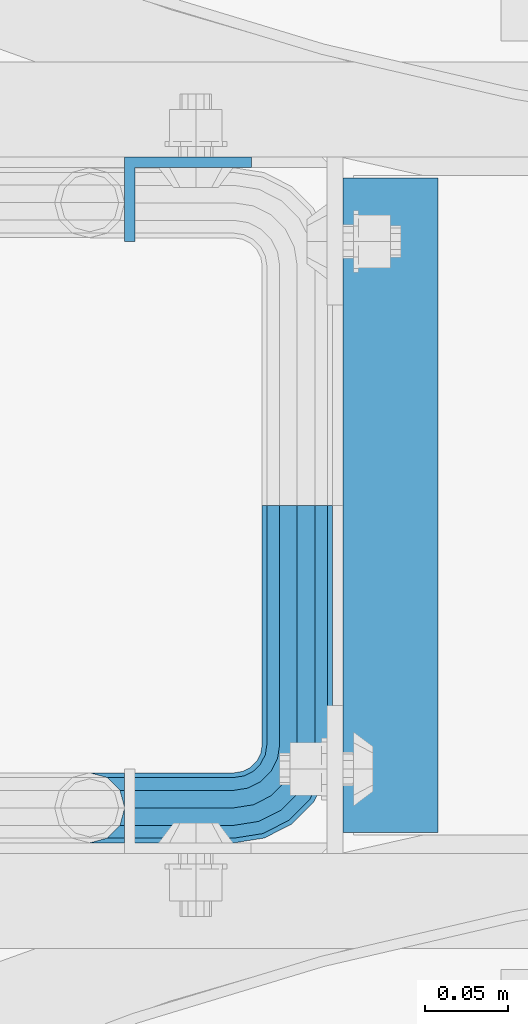
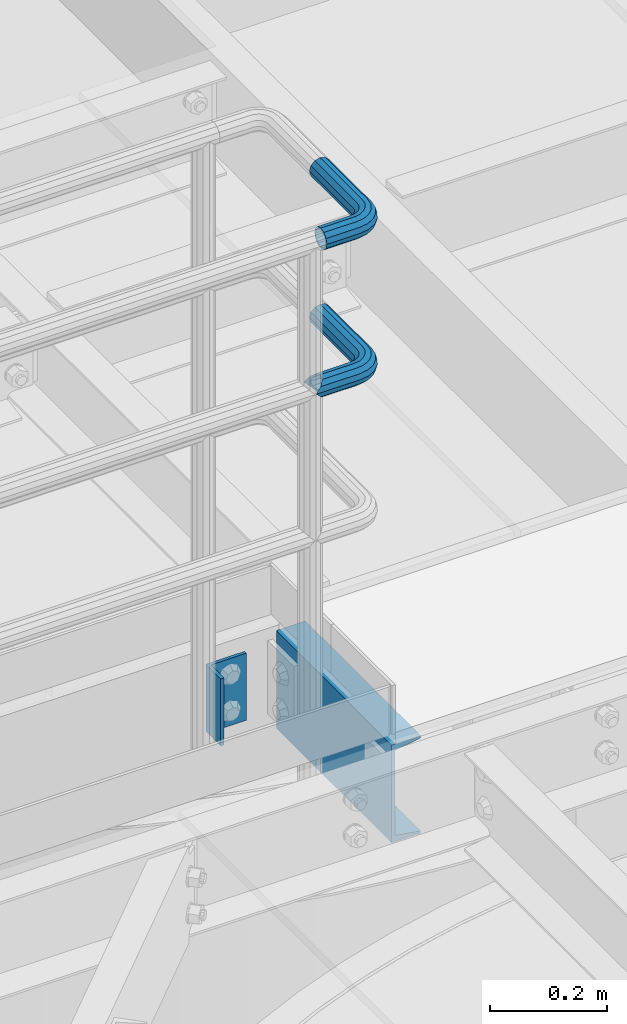
# One storey, part 1114 of 1876: 4 beams, 3 elements without a shape of their own.
"""IFC2X3 building model written with IfcOpenShell, lengths in millimetres."""

from ifc_helpers import new_model, si_unit, frame, origin_with_axes, place, context, subcontext, project, spatial, faceted_brep, material, type_object, element, aggregate, save


model = new_model("IFC2X3")

# Units and contexts
model_context = context("Model", 3, precision=1e-05, world=origin_with_axes())
body_context = subcontext(model_context, "Body", "Model", "MODEL_VIEW")
ifc_project = project(units=[si_unit("LENGTHUNIT", "METRE", prefix="MILLI"), si_unit("AREAUNIT", "SQUARE_METRE"), si_unit("VOLUMEUNIT", "CUBIC_METRE"), si_unit("MASSUNIT", "GRAM", prefix="KILO"), si_unit("TIMEUNIT", "SECOND"), si_unit("PLANEANGLEUNIT", "RADIAN"), si_unit("SOLIDANGLEUNIT", "STERADIAN"), si_unit("THERMODYNAMICTEMPERATUREUNIT", "DEGREE_CELSIUS"), si_unit("LUMINOUSINTENSITYUNIT", "LUMEN")], contexts=[model_context])

# Site, building, storey
site_placement = place(None, origin_with_axes())
site = spatial("IfcSite", under=ifc_project, at=site_placement, CompositionType="ELEMENT")
building_placement = place(site_placement, origin_with_axes())
building = spatial("IfcBuilding", under=site, at=building_placement, Name="Undefined", CompositionType="ELEMENT")
storey_placement = place(building_placement, origin_with_axes())
storey = spatial("IfcBuildingStorey", under=building, at=storey_placement, Name="Undefined", CompositionType="ELEMENT", Elevation=0.0)

# Assembly, beams
assembly_1_placement = place(storey_placement, origin_with_axes())
assembly_1 = element("IfcElementAssembly", 1, at=assembly_1_placement, inside=storey, Name="HANDRAIL", AssemblyPlace="NOTDEFINED", PredefinedType="RIGID_FRAME")
ifc_material_1 = material()
beam_type_1 = type_object("IfcBeamType", Name="PIPE1-1/4STD", PredefinedType="NOTDEFINED")
beam_1_placement = place(assembly_1_placement, frame((4696.96656849878, -11563.3144042962, 8785.225), z_axis=(0.0, 0.0, -1.0), x_axis=(0.0, -1.0, 0.0)))
beam_1 = element("IfcBeam", 2, at=beam_1_placement, type_object=beam_type_1, material=ifc_material_1, Name="HANDRAIL", ObjectType="PIPE1-1/4STD", context=body_context, shape_type="Brep", body=[
    faceted_brep([(192.659041992189, 106.710451704997, 18.2575475625836), (192.659048095087, 106.710451704997, 13.3999551238248), (190.881041992188, 106.234036405587, 15.1779612267255), (182.118041992188, 103.88599926758, 17.5259999999998), (182.118041992188, 103.88599926758, 21.0820000000003), (173.355041992188, 106.234039676121, 15.1779612267255), (171.577048095089, 106.710451704997, 13.3999673296257), (171.577041992188, 106.710451704997, 18.2575475625836), (163.860494429604, 114.42699926758, 10.5409999999993), (163.860494429604, 114.42699926758, -10.5409999999993), (161.036041992187, 124.968002319336, 0.0), (166.940080765462, 111.347419034623, 8.76300000000083), (164.592041992188, 113.695457807897, 0.0), (166.940080765462, 111.347419034623, -8.76300000000083), (171.577048095089, 106.710451704997, -13.3999673296257), (171.577041992188, 106.710451704997, -18.2575475625836), (182.118041992188, 103.88599926758, -17.5259999999998), (182.118041992188, 103.88599926758, -21.0820000000003), (173.355041992188, 106.234039676121, -15.1779612267255), (192.659048095087, 106.710451704997, -13.3999551238248), (192.659041992189, 106.710451704997, -18.2575475625836), (190.881041992188, 106.234036405587, -15.1779612267255), (203.200048095088, 124.96799926758, 0.0), (200.375589554771, 114.42699926758, -10.5409999999993), (200.375589554771, 114.42699926758, 10.5409999999993), (197.296003218913, 111.347406828822, -8.76300000000083), (199.644041992187, 113.695445602096, 0.0), (197.296003218913, 111.347406828822, 8.76300000000083), (0.0, -18.2575475625836, -10.5409999999993), (0.0, -10.5410000000002, -18.2575475625836), (144.018043518066, -10.5409999999983, -18.2575475625836), (144.018043518066, -18.2575475625817, -10.5409999999993), (-4.28826751885936e-09, 0.0, -21.0820000000003), (144.018043518066, 1.81898940354586e-12, -21.0820000000003), (0.0, 10.5410000000002, -18.2575475625836), (144.018043518066, 10.5410000000011, -18.2575475625836), (0.0, 18.2575475625836, -10.5409999999993), (144.018043518066, 18.2575475625854, -10.5409999999993), (9.09494701772928e-13, 21.0820000000003, 0.0), (144.018043518066, 21.0820000000012, 0.0), (0.0, 18.2575475625836, 10.5409999999993), (144.018043518066, 18.2575475625854, 10.5409999999993), (0.0, 10.5410000000002, 18.2575475625836), (144.018043518066, 10.5410000000011, 18.2575475625836), (0.0, 0.0, 21.0820000000003), (144.018043518066, 1.81898940354586e-12, 21.0820000000003), (0.0, -10.5410000000002, 18.2575475625836), (144.018043518066, -10.5409999999983, 18.2575475625836), (0.0, -18.2575475625836, 10.5409999999993), (144.018043518066, -18.2575475625817, 10.5409999999993), (9.09494701772928e-13, -21.0820000000003, 0.0), (144.018043518066, -21.0819999999985, 0.0), (162.306286807647, -18.1854268220595, 0.0), (161.433483004681, -15.4992129264883, 10.5409999999993), (159.048938669939, -8.16034008379211, 18.2575475625836), (155.791590532232, 1.86474665447531, 21.0820000000003), (152.534242394526, 11.8898333927418, 18.2575475625836), (150.149698059784, 19.228706235438, 10.5409999999993), (149.276894256818, 21.9149201310092, 0.0), (150.149698059784, 19.2287062354389, -10.5409999999993), (152.534242394526, 11.8898333927418, -18.2575475625836), (155.791590532232, 1.86474665447531, -21.0820000000003), (159.048938669939, -8.16034008379211, -18.2575475625836), (161.433483004681, -15.4992129264883, -10.5409999999993), (163.860494429606, 38.0999984741229, -10.5409999999993), (161.036041992189, 38.0999984741229, 0.0), (163.860494429606, 38.0999984741229, 10.5409999999993), (171.57704199219, 38.0999984741229, 18.2575475625836), (182.118041992189, 38.099998474122, 21.0820000000003), (192.65904199219, 38.099998474122, 18.2575475625836), (200.375589554773, 38.099998474122, 10.5409999999993), (203.200041992188, 38.0999984741229, 0.0), (182.118041992189, 38.099998474122, -21.0820000000003), (171.57704199219, 38.0999984741229, -18.2575475625836), (192.65904199219, 38.099998474122, -18.2575475625836), (200.375589554773, 38.099998474122, -10.5409999999993), (162.889335756752, 31.9683439324062, -10.5409999999993), (170.228208599448, 29.5837995976653, -18.2575475625836), (160.203121861181, 32.841147735372, 0.0), (162.889335756752, 31.9683439324062, 10.5409999999993), (170.228208599448, 29.5837995976653, 18.2575475625836), (180.253295337716, 26.3264514599587, 21.0820000000003), (190.278382075983, 23.069103322252, 18.2575475625836), (197.617254918679, 20.6845589875102, 10.5409999999993), (200.303468814251, 19.8117551845444, 0.0), (197.617254918679, 20.6845589875102, -10.5409999999993), (190.278382075983, 23.069103322252, -18.2575475625836), (180.253295337716, 26.3264514599587, -21.0820000000003), (166.313741631582, 21.9012256030801, -18.2575475625836), (174.841589769288, 15.7053812586637, -21.0820000000003), (160.07092351555, 26.436898458981, -10.5409999999993), (157.785893493878, 28.0970699474965, 0.0), (160.07092351555, 26.436898458981, 10.5409999999993), (166.313741631582, 21.9012256030801, 18.2575475625836), (174.841589769288, 15.7053812586637, 21.0820000000003), (183.369437906993, 9.50953691424729, 18.2575475625836), (189.612256023025, 4.97386405834641, 10.5409999999993), (191.897286044699, 3.31369256983089, 0.0), (189.612256023025, 4.97386405834641, -10.5409999999993), (183.369437906993, 9.50953691424729, -18.2575475625836), (166.412660733527, 7.27645222290266, -21.0820000000003), (172.608505077944, -1.25139591480183, -18.2575475625836), (160.216816389111, 15.8043003606081, -18.2575475625836), (155.681143533209, 22.0471184766402, -10.5409999999993), (154.020972044695, 24.3321484983135, 0.0), (155.681143533209, 22.0471184766402, 10.5409999999993), (160.216816389111, 15.8043003606081, 18.2575475625836), (166.412660733527, 7.27645222290266, 21.0820000000003), (172.608505077944, -1.25139591480183, 18.2575475625836), (177.144177933844, -7.49421403083397, 10.5409999999993), (178.80434942236, -9.77924405250724, 0.0), (177.144177933844, -7.49421403083397, -10.5409999999993), (0.0, -15.1779612267264, -8.76300000000083), (0.0, -8.76299999999992, -15.1779612267255), (0.0, 0.0, -17.5259999999998), (0.0, 8.76299999999992, -15.1779612267255), (0.0, 15.1779612267264, -8.76300000000083), (0.0, 17.5259999999998, 0.0), (0.0, 15.1779612267264, 8.76300000000083), (0.0, 8.76299999999992, 15.1779612267255), (0.0, 0.0, 17.5259999999998), (0.0, -8.76299999999992, 15.1779612267255), (0.0, -15.1779612267264, 8.76300000000083), (0.0, -17.5259999999998, 0.0), (144.018043518066, -8.7629999999981, 15.1779612267255), (144.018043518066, -15.1779612267246, 8.76300000000083), (144.018043518066, -17.5259999999989, 0.0), (144.018043518066, -15.1779612267246, -8.76300000000083), (144.018043518066, -8.76299999999901, -15.1779612267255), (144.018043518066, 1.81898940354586e-12, -17.5259999999998), (144.018043518066, 8.76300000000174, -15.1779612267255), (144.018043518066, 15.1779612267273, -8.76300000000083), (144.018043518066, 17.5260000000017, 0.0), (144.018043518066, 15.1779612267273, 8.76300000000083), (144.018043518066, 8.76300000000174, 15.1779612267255), (144.018043518066, 1.81898940354586e-12, 17.5259999999998), (155.791590532232, 1.86474665447531, 17.5259999999998), (158.49950645394, -6.46936159781944, 15.1779612267255), (160.481838491256, -12.5703522742779, 8.76300000000083), (161.207422375648, -14.8034698501133, 0.0), (160.481838491256, -12.5703522742779, -8.76300000000083), (158.49950645394, -6.46936159781944, -15.1779612267255), (155.791590532232, 1.86474665447531, -17.5259999999998), (153.083674610523, 10.1988549067692, -15.1779612267255), (151.101342573209, 16.2998455832276, -8.76300000000083), (150.375758688817, 18.5329631590639, 0.0), (151.101342573209, 16.2998455832276, 8.76300000000083), (153.083674610523, 10.1988549067692, 15.1779612267255), (161.261898567687, 14.3658681446095, 15.1779612267255), (166.412660733527, 7.27645222290266, 17.5259999999998), (157.491278964588, 19.5556807952871, 8.76300000000083), (156.111136401847, 21.4552840663164, 0.0), (157.491278964588, 19.5556807952871, -8.76300000000083), (161.261898567687, 14.3658681446095, -15.1779612267255), (166.412660733527, 7.27645222290266, -17.5259999999998), (171.563422899368, 0.187036301196713, -15.1779612267255), (175.334042502465, -5.00277634948088, -8.76300000000083), (176.714185065208, -6.90237962051015, 0.0), (175.334042502465, -5.00277634948088, 8.76300000000083), (171.563422899368, 0.187036301196713, 15.1779612267255), (174.841589769288, 15.7053812586637, 17.5259999999998), (181.931005690994, 10.5546190928235, 15.1779612267255), (167.752173847581, 20.8561434245039, 15.1779612267255), (162.562361196904, 24.6267630276025, 8.76300000000083), (160.662757925875, 26.0069055903441, 0.0), (162.562361196904, 24.6267630276025, -8.76300000000083), (167.752173847581, 20.8561434245039, -15.1779612267255), (174.841589769288, 15.7053812586637, -17.5259999999998), (181.931005690994, 10.5546190928235, -15.1779612267255), (187.120818341671, 6.78399948972492, -8.76300000000083), (189.020421612702, 5.40385692698328, 0.0), (187.120818341671, 6.78399948972492, 8.76300000000083), (188.587403590011, 23.6185355382504, 15.1779612267255), (194.688394266468, 21.6362035009352, 8.76300000000083), (180.253295337716, 26.3264514599587, 17.5259999999998), (171.919187085421, 29.0343673816669, 15.1779612267255), (165.818196408964, 31.0166994189813, 8.76300000000083), (163.585078833126, 31.7422833033743, 0.0), (165.818196408964, 31.0166994189813, -8.76300000000083), (171.919187085421, 29.0343673816669, -15.1779612267255), (180.253295337716, 26.3264514599587, -17.5259999999998), (188.587403590011, 23.6185355382504, -15.1779612267255), (194.688394266468, 21.6362035009352, -8.76300000000083), (196.921511842305, 20.9106196165421, 0.0), (197.296003218915, 38.099998474122, 8.76300000000083), (199.644041992187, 38.0999984741229, 0.0), (190.88104199219, 38.099998474122, 15.1779612267255), (182.118041992189, 38.099998474122, 17.5259999999998), (173.355041992188, 38.099998474122, 15.1779612267255), (166.940080765464, 38.0999984741229, 8.76300000000083), (164.592041992189, 38.0999984741229, 0.0), (166.940080765464, 38.0999984741229, -8.76300000000083), (173.355041992188, 38.0999984741229, -15.1779612267255), (182.118041992189, 38.099998474122, -17.5259999999998), (190.88104199219, 38.099998474122, -15.1779612267255), (197.296003218915, 38.099998474122, -8.76300000000083)], [[[0, 1, 2, 3, 4]], [[4, 3, 5, 6, 7]], [[8, 9, 10]], [[7, 6, 11, 12, 13, 14, 15, 9, 8]], [[16, 17, 15, 14, 18]], [[19, 20, 17, 16, 21]], [[22, 23, 24]], [[24, 23, 20, 19, 25, 26, 27, 1, 0]], [[28, 29, 30, 31]], [[29, 32, 33, 30]], [[32, 34, 35, 33]], [[34, 36, 37, 35]], [[36, 38, 39, 37]], [[38, 40, 41, 39]], [[40, 42, 43, 41]], [[42, 44, 45, 43]], [[44, 46, 47, 45]], [[46, 48, 49, 47]], [[48, 50, 51, 49]], [[49, 51, 52, 53]], [[47, 49, 53, 54]], [[45, 47, 54, 55]], [[43, 45, 55, 56]], [[41, 43, 56, 57]], [[39, 41, 57, 58]], [[37, 39, 58, 59]], [[35, 37, 59, 60]], [[33, 35, 60, 61]], [[30, 33, 61, 62]], [[31, 30, 62, 63]], [[64, 65, 10, 9]], [[65, 66, 8, 10]], [[66, 67, 7, 8]], [[67, 68, 4, 7]], [[68, 69, 0, 4]], [[69, 70, 24, 0]], [[70, 71, 22, 24]], [[72, 73, 15, 17]], [[74, 72, 17, 20]], [[75, 74, 20, 23]], [[71, 75, 23, 22]], [[73, 64, 9, 15]], [[76, 64, 73, 77]], [[78, 65, 64, 76]], [[79, 66, 65, 78]], [[80, 67, 66, 79]], [[81, 68, 67, 80]], [[82, 69, 68, 81]], [[83, 70, 69, 82]], [[84, 71, 70, 83]], [[85, 75, 71, 84]], [[86, 74, 75, 85]], [[87, 72, 74, 86]], [[77, 73, 72, 87]], [[88, 77, 87, 89]], [[90, 76, 77, 88]], [[91, 78, 76, 90]], [[92, 79, 78, 91]], [[93, 80, 79, 92]], [[94, 81, 80, 93]], [[95, 82, 81, 94]], [[96, 83, 82, 95]], [[97, 84, 83, 96]], [[98, 85, 84, 97]], [[99, 86, 85, 98]], [[89, 87, 86, 99]], [[100, 89, 99, 101]], [[102, 88, 89, 100]], [[103, 90, 88, 102]], [[104, 91, 90, 103]], [[105, 92, 91, 104]], [[106, 93, 92, 105]], [[107, 94, 93, 106]], [[108, 95, 94, 107]], [[109, 96, 95, 108]], [[110, 97, 96, 109]], [[111, 98, 97, 110]], [[101, 99, 98, 111]], [[62, 101, 111, 63]], [[61, 100, 101, 62]], [[60, 102, 100, 61]], [[59, 103, 102, 60]], [[58, 104, 103, 59]], [[57, 105, 104, 58]], [[56, 106, 105, 57]], [[55, 107, 106, 56]], [[54, 108, 107, 55]], [[53, 109, 108, 54]], [[52, 110, 109, 53]], [[63, 111, 110, 52]], [[51, 31, 63, 52]], [[50, 28, 31, 51]], [[48, 46, 44, 42, 40, 38, 36, 34, 32, 29, 28, 50], [112, 113, 114, 115, 116, 117, 118, 119, 120, 121, 122, 123]], [[122, 121, 124, 125]], [[123, 122, 125, 126]], [[112, 123, 126, 127]], [[113, 112, 127, 128]], [[114, 113, 128, 129]], [[115, 114, 129, 130]], [[116, 115, 130, 131]], [[117, 116, 131, 132]], [[118, 117, 132, 133]], [[119, 118, 133, 134]], [[120, 119, 134, 135]], [[121, 120, 135, 124]], [[124, 135, 136, 137]], [[125, 124, 137, 138]], [[126, 125, 138, 139]], [[127, 126, 139, 140]], [[128, 127, 140, 141]], [[129, 128, 141, 142]], [[130, 129, 142, 143]], [[131, 130, 143, 144]], [[132, 131, 144, 145]], [[133, 132, 145, 146]], [[134, 133, 146, 147]], [[135, 134, 147, 136]], [[147, 148, 149, 136]], [[146, 150, 148, 147]], [[145, 151, 150, 146]], [[144, 152, 151, 145]], [[143, 153, 152, 144]], [[142, 154, 153, 143]], [[141, 155, 154, 142]], [[140, 156, 155, 141]], [[139, 157, 156, 140]], [[138, 158, 157, 139]], [[137, 159, 158, 138]], [[136, 149, 159, 137]], [[149, 160, 161, 159]], [[148, 162, 160, 149]], [[150, 163, 162, 148]], [[151, 164, 163, 150]], [[152, 165, 164, 151]], [[153, 166, 165, 152]], [[154, 167, 166, 153]], [[155, 168, 167, 154]], [[156, 169, 168, 155]], [[157, 170, 169, 156]], [[158, 171, 170, 157]], [[159, 161, 171, 158]], [[161, 172, 173, 171]], [[160, 174, 172, 161]], [[162, 175, 174, 160]], [[163, 176, 175, 162]], [[164, 177, 176, 163]], [[165, 178, 177, 164]], [[166, 179, 178, 165]], [[167, 180, 179, 166]], [[168, 181, 180, 167]], [[169, 182, 181, 168]], [[170, 183, 182, 169]], [[171, 173, 183, 170]], [[173, 184, 185, 183]], [[172, 186, 184, 173]], [[174, 187, 186, 172]], [[175, 188, 187, 174]], [[176, 189, 188, 175]], [[177, 190, 189, 176]], [[178, 191, 190, 177]], [[179, 192, 191, 178]], [[180, 193, 192, 179]], [[181, 194, 193, 180]], [[182, 195, 194, 181]], [[183, 185, 195, 182]], [[195, 185, 26, 25]], [[21, 194, 195, 25, 19]], [[193, 194, 21, 16]], [[192, 193, 16, 18]], [[13, 191, 192, 18, 14]], [[190, 191, 13, 12]], [[189, 190, 12, 11]], [[188, 189, 11, 6, 5]], [[187, 188, 5, 3]], [[186, 187, 3, 2]], [[184, 186, 2, 1, 27]], [[185, 184, 27, 26]]]),
])
beam_2_placement = place(assembly_1_placement, frame((4696.96656849878, -11563.3144042962, 9090.025), z_axis=(0.0, 0.0, -1.0), x_axis=(0.0, -1.0, 0.0)))
beam_2 = element("IfcBeam", 3, at=beam_2_placement, type_object=beam_type_1, material=ifc_material_1, Name="HANDRAIL", ObjectType="PIPE1-1/4STD", context=body_context, shape_type="Brep", body=[
    faceted_brep([(9.09494701772928e-13, -21.0820000000003, 0.0), (0.0, -18.2575475625836, -10.5409999999993), (144.018043518066, -18.2575475625817, -10.5409999999993), (144.018043518066, -21.0819999999985, 0.0), (0.0, -10.5410000000002, -18.2575475625836), (144.018043518066, -10.5409999999983, -18.2575475625836), (-4.28826751885936e-09, 0.0, -21.0820000000003), (144.018043518066, 1.81898940354586e-12, -21.0820000000003), (0.0, 10.5410000000002, -18.2575475625836), (144.018043518066, 10.5410000000011, -18.2575475625836), (0.0, 18.2575475625836, -10.5409999999993), (144.018043518066, 18.2575475625854, -10.5409999999993), (9.09494701772928e-13, 21.0820000000003, 0.0), (144.018043518066, 21.0820000000012, 0.0), (0.0, 18.2575475625836, 10.5409999999993), (144.018043518066, 18.2575475625854, 10.5409999999993), (0.0, 10.5410000000002, 18.2575475625836), (144.018043518066, 10.5410000000011, 18.2575475625836), (0.0, 0.0, 21.0820000000003), (144.018043518066, 1.81898940354586e-12, 21.0820000000003), (0.0, -10.5410000000002, 18.2575475625836), (144.018043518066, -10.5409999999983, 18.2575475625836), (0.0, -18.2575475625836, 10.5409999999993), (144.018043518066, -18.2575475625817, 10.5409999999993), (0.0, -17.5259999999998, 0.0), (0.0, -15.1779612267264, 8.76300000000083), (144.018043518066, -15.1779612267246, 8.76300000000083), (144.018043518066, -17.5259999999989, 0.0), (0.0, -8.76299999999992, 15.1779612267255), (144.018043518066, -8.7629999999981, 15.1779612267255), (0.0, 0.0, 17.5259999999998), (144.018043518066, 1.81898940354586e-12, 17.5259999999998), (0.0, 8.76299999999992, 15.1779612267255), (144.018043518066, 8.76300000000174, 15.1779612267255), (0.0, 15.1779612267264, 8.76300000000083), (144.018043518066, 15.1779612267273, 8.76300000000083), (0.0, 17.5259999999998, 0.0), (144.018043518066, 17.5260000000017, 0.0), (0.0, 15.1779612267264, -8.76300000000083), (144.018043518066, 15.1779612267273, -8.76300000000083), (0.0, 8.76299999999992, -15.1779612267255), (144.018043518066, 8.76300000000174, -15.1779612267255), (0.0, 0.0, -17.5259999999998), (144.018043518066, 1.81898940354586e-12, -17.5259999999998), (0.0, -8.76299999999992, -15.1779612267255), (144.018043518066, -8.76299999999901, -15.1779612267255), (0.0, -15.1779612267264, -8.76300000000083), (144.018043518066, -15.1779612267246, -8.76300000000083), (162.306286807647, -18.1854268220595, 0.0), (161.433483004681, -15.4992129264883, 10.5409999999993), (159.048938669939, -8.16034008379211, 18.2575475625836), (155.791590532232, 1.86474665447531, 21.0820000000003), (152.534242394526, 11.8898333927418, 18.2575475625836), (150.149698059784, 19.228706235438, 10.5409999999993), (149.276894256818, 21.9149201310092, 0.0), (150.149698059784, 19.2287062354389, -10.5409999999993), (152.534242394526, 11.8898333927418, -18.2575475625836), (155.791590532232, 1.86474665447531, -21.0820000000003), (159.048938669939, -8.16034008379211, -18.2575475625836), (161.433483004681, -15.4992129264883, -10.5409999999993), (161.207422375648, -14.8034698501133, 0.0), (160.481838491256, -12.5703522742779, -8.76300000000083), (158.49950645394, -6.46936159781944, -15.1779612267255), (155.791590532232, 1.86474665447531, -17.5259999999998), (153.083674610523, 10.1988549067692, -15.1779612267255), (151.101342573209, 16.2998455832276, -8.76300000000083), (150.375758688817, 18.5329631590639, 0.0), (151.101342573209, 16.2998455832276, 8.76300000000083), (153.083674610523, 10.1988549067692, 15.1779612267255), (155.791590532232, 1.86474665447531, 17.5259999999998), (158.49950645394, -6.46936159781944, 15.1779612267255), (160.481838491256, -12.5703522742779, 8.76300000000083), (172.608505077944, -1.25139591480183, -18.2575475625836), (177.144177933844, -7.49421403083397, -10.5409999999993), (166.412660733527, 7.27645222290266, -21.0820000000003), (160.216816389111, 15.8043003606081, -18.2575475625836), (155.681143533209, 22.0471184766402, -10.5409999999993), (154.020972044695, 24.3321484983135, 0.0), (155.681143533209, 22.0471184766402, 10.5409999999993), (160.216816389111, 15.8043003606081, 18.2575475625836), (166.412660733527, 7.27645222290266, 21.0820000000003), (172.608505077944, -1.25139591480183, 18.2575475625836), (177.144177933844, -7.49421403083397, 10.5409999999993), (178.80434942236, -9.77924405250724, 0.0), (175.334042502465, -5.00277634948088, 8.76300000000083), (176.714185065208, -6.90237962051015, 0.0), (171.563422899368, 0.187036301196713, 15.1779612267255), (166.412660733527, 7.27645222290266, 17.5259999999998), (161.261898567687, 14.3658681446095, 15.1779612267255), (157.491278964588, 19.5556807952871, 8.76300000000083), (156.111136401847, 21.4552840663164, 0.0), (157.491278964588, 19.5556807952871, -8.76300000000083), (161.261898567687, 14.3658681446095, -15.1779612267255), (166.412660733527, 7.27645222290266, -17.5259999999998), (171.563422899368, 0.187036301196713, -15.1779612267255), (175.334042502465, -5.00277634948088, -8.76300000000083), (183.369437906993, 9.50953691424729, -18.2575475625836), (189.612256023025, 4.97386405834641, -10.5409999999993), (174.841589769288, 15.7053812586637, -21.0820000000003), (166.313741631582, 21.9012256030801, -18.2575475625836), (160.07092351555, 26.436898458981, -10.5409999999993), (157.785893493878, 28.0970699474965, 0.0), (160.07092351555, 26.436898458981, 10.5409999999993), (166.313741631582, 21.9012256030801, 18.2575475625836), (174.841589769288, 15.7053812586637, 21.0820000000003), (183.369437906993, 9.50953691424729, 18.2575475625836), (189.612256023025, 4.97386405834641, 10.5409999999993), (191.897286044699, 3.31369256983089, 0.0), (187.120818341671, 6.78399948972492, 8.76300000000083), (189.020421612702, 5.40385692698328, 0.0), (181.931005690994, 10.5546190928235, 15.1779612267255), (174.841589769288, 15.7053812586637, 17.5259999999998), (167.752173847581, 20.8561434245039, 15.1779612267255), (162.562361196904, 24.6267630276025, 8.76300000000083), (160.662757925875, 26.0069055903441, 0.0), (162.562361196904, 24.6267630276025, -8.76300000000083), (167.752173847581, 20.8561434245039, -15.1779612267255), (174.841589769288, 15.7053812586637, -17.5259999999998), (181.931005690994, 10.5546190928235, -15.1779612267255), (187.120818341671, 6.78399948972492, -8.76300000000083), (190.278382075983, 23.069103322252, -18.2575475625836), (197.617254918679, 20.6845589875102, -10.5409999999993), (180.253295337716, 26.3264514599587, -21.0820000000003), (170.228208599448, 29.5837995976653, -18.2575475625836), (162.889335756752, 31.9683439324062, -10.5409999999993), (160.203121861181, 32.841147735372, 0.0), (162.889335756752, 31.9683439324062, 10.5409999999993), (170.228208599448, 29.5837995976653, 18.2575475625836), (180.253295337716, 26.3264514599587, 21.0820000000003), (190.278382075983, 23.069103322252, 18.2575475625836), (197.617254918679, 20.6845589875102, 10.5409999999993), (200.303468814251, 19.8117551845444, 0.0), (194.688394266468, 21.6362035009352, 8.76300000000083), (196.921511842305, 20.9106196165421, 0.0), (188.587403590011, 23.6185355382504, 15.1779612267255), (180.253295337716, 26.3264514599587, 17.5259999999998), (171.919187085421, 29.0343673816669, 15.1779612267255), (165.818196408964, 31.0166994189813, 8.76300000000083), (163.585078833126, 31.7422833033743, 0.0), (165.818196408964, 31.0166994189813, -8.76300000000083), (171.919187085421, 29.0343673816669, -15.1779612267255), (180.253295337716, 26.3264514599587, -17.5259999999998), (188.587403590011, 23.6185355382504, -15.1779612267255), (194.688394266468, 21.6362035009352, -8.76300000000083), (192.65904199219, 38.099998474122, -18.2575475625836), (200.375589554773, 38.099998474122, -10.5409999999993), (182.118041992189, 38.099998474122, -21.0820000000003), (171.57704199219, 38.0999984741229, -18.2575475625836), (163.860494429606, 38.0999984741229, -10.5409999999993), (161.036041992189, 38.0999984741229, 0.0), (163.860494429606, 38.0999984741229, 10.5409999999993), (171.57704199219, 38.0999984741229, 18.2575475625836), (182.118041992189, 38.099998474122, 21.0820000000003), (192.65904199219, 38.099998474122, 18.2575475625836), (200.375589554773, 38.099998474122, 10.5409999999993), (203.200041992188, 38.0999984741229, 0.0), (197.296003218915, 38.099998474122, 8.76300000000083), (199.644041992187, 38.0999984741229, 0.0), (190.88104199219, 38.099998474122, 15.1779612267255), (182.118041992189, 38.099998474122, 17.5259999999998), (173.355041992188, 38.099998474122, 15.1779612267255), (166.940080765464, 38.0999984741229, 8.76300000000083), (164.592041992189, 38.0999984741229, 0.0), (166.940080765464, 38.0999984741229, -8.76300000000083), (173.355041992188, 38.0999984741229, -15.1779612267255), (182.118041992189, 38.099998474122, -17.5259999999998), (190.88104199219, 38.099998474122, -15.1779612267255), (197.296003218915, 38.099998474122, -8.76300000000083), (200.375589554771, 103.933624267578, -10.5409999999993), (203.200041992188, 103.933624267578, 0.0), (192.659041992187, 103.933624267578, -18.2575475625836), (182.118041992188, 103.933624267578, -21.0820000000003), (171.577041992188, 103.933624267578, -18.2575475625836), (163.860494429604, 103.933624267578, -10.5409999999993), (161.036041992187, 103.933624267578, 0.0), (163.860494429604, 103.933624267578, 10.5409999999993), (171.577041992188, 103.933624267578, 18.2575475625836), (182.118041992188, 103.933624267578, 21.0820000000003), (192.659041992187, 103.933624267578, 18.2575475625836), (200.375589554771, 103.933624267578, 10.5409999999993), (197.296003218913, 103.933624267578, 8.76300000000083), (199.644041992187, 103.933624267578, 0.0), (190.881041992188, 103.933624267578, 15.1779612267255), (182.118041992188, 103.933624267578, 17.5259999999998), (173.355041992187, 103.933624267578, 15.1779612267255), (166.940080765462, 103.933624267578, 8.76300000000083), (164.592041992188, 103.933624267578, 0.0), (166.940080765462, 103.933624267578, -8.76300000000083), (173.355041992187, 103.933624267578, -15.1779612267255), (182.118041992188, 103.933624267578, -17.5259999999998), (190.881041992188, 103.933624267578, -15.1779612267255), (197.296003218913, 103.933624267578, -8.76300000000083)], [[[0, 1, 2, 3]], [[1, 4, 5, 2]], [[4, 6, 7, 5]], [[6, 8, 9, 7]], [[8, 10, 11, 9]], [[10, 12, 13, 11]], [[12, 14, 15, 13]], [[14, 16, 17, 15]], [[16, 18, 19, 17]], [[18, 20, 21, 19]], [[20, 22, 23, 21]], [[22, 0, 3, 23]], [[24, 25, 26, 27]], [[25, 28, 29, 26]], [[28, 30, 31, 29]], [[30, 32, 33, 31]], [[32, 34, 35, 33]], [[34, 36, 37, 35]], [[36, 38, 39, 37]], [[38, 40, 41, 39]], [[40, 42, 43, 41]], [[42, 44, 45, 43]], [[44, 46, 47, 45]], [[46, 24, 27, 47]], [[22, 20, 18, 16, 14, 12, 10, 8, 6, 4, 1, 0], [46, 44, 42, 40, 38, 36, 34, 32, 30, 28, 25, 24]], [[23, 3, 48, 49]], [[21, 23, 49, 50]], [[19, 21, 50, 51]], [[17, 19, 51, 52]], [[15, 17, 52, 53]], [[13, 15, 53, 54]], [[11, 13, 54, 55]], [[9, 11, 55, 56]], [[7, 9, 56, 57]], [[5, 7, 57, 58]], [[2, 5, 58, 59]], [[3, 2, 59, 48]], [[47, 27, 60, 61]], [[45, 47, 61, 62]], [[43, 45, 62, 63]], [[41, 43, 63, 64]], [[39, 41, 64, 65]], [[37, 39, 65, 66]], [[35, 37, 66, 67]], [[33, 35, 67, 68]], [[31, 33, 68, 69]], [[29, 31, 69, 70]], [[26, 29, 70, 71]], [[27, 26, 71, 60]], [[58, 72, 73, 59]], [[57, 74, 72, 58]], [[56, 75, 74, 57]], [[55, 76, 75, 56]], [[54, 77, 76, 55]], [[53, 78, 77, 54]], [[52, 79, 78, 53]], [[51, 80, 79, 52]], [[50, 81, 80, 51]], [[49, 82, 81, 50]], [[48, 83, 82, 49]], [[59, 73, 83, 48]], [[71, 84, 85, 60]], [[70, 86, 84, 71]], [[69, 87, 86, 70]], [[68, 88, 87, 69]], [[67, 89, 88, 68]], [[66, 90, 89, 67]], [[65, 91, 90, 66]], [[64, 92, 91, 65]], [[63, 93, 92, 64]], [[62, 94, 93, 63]], [[61, 95, 94, 62]], [[60, 85, 95, 61]], [[72, 96, 97, 73]], [[74, 98, 96, 72]], [[75, 99, 98, 74]], [[76, 100, 99, 75]], [[77, 101, 100, 76]], [[78, 102, 101, 77]], [[79, 103, 102, 78]], [[80, 104, 103, 79]], [[81, 105, 104, 80]], [[82, 106, 105, 81]], [[83, 107, 106, 82]], [[73, 97, 107, 83]], [[84, 108, 109, 85]], [[86, 110, 108, 84]], [[87, 111, 110, 86]], [[88, 112, 111, 87]], [[89, 113, 112, 88]], [[90, 114, 113, 89]], [[91, 115, 114, 90]], [[92, 116, 115, 91]], [[93, 117, 116, 92]], [[94, 118, 117, 93]], [[95, 119, 118, 94]], [[85, 109, 119, 95]], [[96, 120, 121, 97]], [[98, 122, 120, 96]], [[99, 123, 122, 98]], [[100, 124, 123, 99]], [[101, 125, 124, 100]], [[102, 126, 125, 101]], [[103, 127, 126, 102]], [[104, 128, 127, 103]], [[105, 129, 128, 104]], [[106, 130, 129, 105]], [[107, 131, 130, 106]], [[97, 121, 131, 107]], [[108, 132, 133, 109]], [[110, 134, 132, 108]], [[111, 135, 134, 110]], [[112, 136, 135, 111]], [[113, 137, 136, 112]], [[114, 138, 137, 113]], [[115, 139, 138, 114]], [[116, 140, 139, 115]], [[117, 141, 140, 116]], [[118, 142, 141, 117]], [[119, 143, 142, 118]], [[109, 133, 143, 119]], [[120, 144, 145, 121]], [[122, 146, 144, 120]], [[123, 147, 146, 122]], [[124, 148, 147, 123]], [[125, 149, 148, 124]], [[126, 150, 149, 125]], [[127, 151, 150, 126]], [[128, 152, 151, 127]], [[129, 153, 152, 128]], [[130, 154, 153, 129]], [[131, 155, 154, 130]], [[121, 145, 155, 131]], [[132, 156, 157, 133]], [[134, 158, 156, 132]], [[135, 159, 158, 134]], [[136, 160, 159, 135]], [[137, 161, 160, 136]], [[138, 162, 161, 137]], [[139, 163, 162, 138]], [[140, 164, 163, 139]], [[141, 165, 164, 140]], [[142, 166, 165, 141]], [[143, 167, 166, 142]], [[133, 157, 167, 143]], [[155, 145, 168, 169]], [[145, 144, 170, 168]], [[144, 146, 171, 170]], [[146, 147, 172, 171]], [[147, 148, 173, 172]], [[148, 149, 174, 173]], [[149, 150, 175, 174]], [[150, 151, 176, 175]], [[151, 152, 177, 176]], [[152, 153, 178, 177]], [[153, 154, 179, 178]], [[154, 155, 169, 179]], [[157, 156, 180, 181]], [[156, 158, 182, 180]], [[158, 159, 183, 182]], [[159, 160, 184, 183]], [[160, 161, 185, 184]], [[161, 162, 186, 185]], [[162, 163, 187, 186]], [[163, 164, 188, 187]], [[164, 165, 189, 188]], [[165, 166, 190, 189]], [[166, 167, 191, 190]], [[167, 157, 181, 191]], [[170, 171, 172, 173, 174, 175, 176, 177, 178, 179, 169, 168], [182, 183, 184, 185, 186, 187, 188, 189, 190, 191, 181, 180]]]),
])
aggregate(assembly_1, [beam_1, beam_2])

# Assembly, beam
assembly_2_placement = place(storey_placement, origin_with_axes())
assembly_2 = element("IfcElementAssembly", 4, at=assembly_2_placement, inside=storey, Name="HANDRAIL", AssemblyPlace="NOTDEFINED", PredefinedType="RIGID_FRAME")
ifc_material_2 = material(Name="STEEL/A36")
beam_type_2 = type_object("IfcBeamType", Name="L3X2X1/4", PredefinedType="NOTDEFINED")
beam_3_placement = place(assembly_2_placement, frame((4631.18674593762, -11379.1643554687, 7966.075), z_axis=(1.0, 0.0, 0.0), x_axis=(0.0, 0.0, -1.0)))
beam_3 = element("IfcBeam", 5, at=beam_3_placement, type_object=beam_type_2, material=ifc_material_2, Name="ANGLE", ObjectType="L3X2X1/4", context=body_context, shape_type="Brep", body=[
    faceted_brep([(0.0, 25.3999999999996, -38.1000000000004), (0.0, 25.3999999999996, 38.1000000000004), (139.7, 25.3999999999996, 38.1000000000004), (139.7, 25.3999999999996, -38.1000000000004), (0.0, 19.0500000000002, 38.1000000000004), (139.7, 19.0500000000002, 38.1000000000004), (0.0, 19.0500000000002, -31.75), (139.7, 19.0500000000002, -31.75), (0.0, -25.3999999999996, -31.75), (139.7, -25.3999999999996, -31.75), (0.0, -25.3999999999996, -38.1000000000004), (139.7, -25.3999999999996, -38.1000000000004)], [[[0, 1, 2, 3]], [[1, 4, 5, 2]], [[4, 6, 7, 5]], [[6, 8, 9, 7]], [[8, 10, 11, 9]], [[10, 0, 3, 11]], [[5, 7, 9, 11, 3, 2]], [[10, 8, 6, 4, 1, 0]]]),
])
aggregate(assembly_2, [beam_3])

assembly_3_placement = place(storey_placement, origin_with_axes())
assembly_3 = element("IfcElementAssembly", 6, at=assembly_3_placement, inside=storey, Name="BEAM", AssemblyPlace="NOTDEFINED", PredefinedType="RIGID_FRAME")
beam_type_3 = type_object("IfcBeamType", Name="C8X11.5", PredefinedType="NOTDEFINED")
beam_4_placement = place(assembly_3_placement, frame((4752.97643150122, -11772.8644531238, 7896.225), z_axis=(0.0, 0.0, 1.0), x_axis=(0.0, 1.0, 0.0)))
beam_4 = element("IfcBeam", 7, at=beam_4_placement, type_object=beam_type_3, material=ifc_material_2, Name="BEAM", ObjectType="C8X11.5", context=body_context, shape_type="Brep", body=[
    faceted_brep([(12.7000000000007, 28.5749999999998, -101.6), (12.7000000000007, 28.5749999999998, 101.6), (406.400097655021, 28.5749999999998, 101.6), (406.400097655021, 28.5749999999998, -101.6), (12.7000000000007, -28.5749999999998, 101.6), (406.400097655021, -28.5749999999998, 101.6), (12.7000000000007, -28.5749999999998, 96.8355949999996), (406.400097655021, -28.5749999999998, 96.8355949999996), (12.7000000000007, 22.2250000000004, 88.3723149999996), (406.400097655021, 22.2250000000004, 88.3723149999996), (12.7000000000007, 22.2250000000004, -88.3723149999996), (406.400097655021, 22.2250000000004, -88.3723149999996), (12.7000000000007, -28.5749999999998, -96.8355949999996), (406.400097655021, -28.5749999999998, -96.8355949999996), (12.7000000000007, -28.5749999999998, -101.6), (406.400097655021, -28.5749999999998, -101.6)], [[[0, 1, 2, 3]], [[1, 4, 5, 2]], [[4, 6, 7, 5]], [[6, 8, 9, 7]], [[8, 10, 11, 9]], [[10, 12, 13, 11]], [[12, 14, 15, 13]], [[14, 0, 3, 15]], [[5, 7, 9, 11, 13, 15, 3, 2]], [[14, 12, 10, 8, 6, 4, 1, 0]]]),
])
aggregate(assembly_3, [beam_4])

save(model, "model.ifc")
